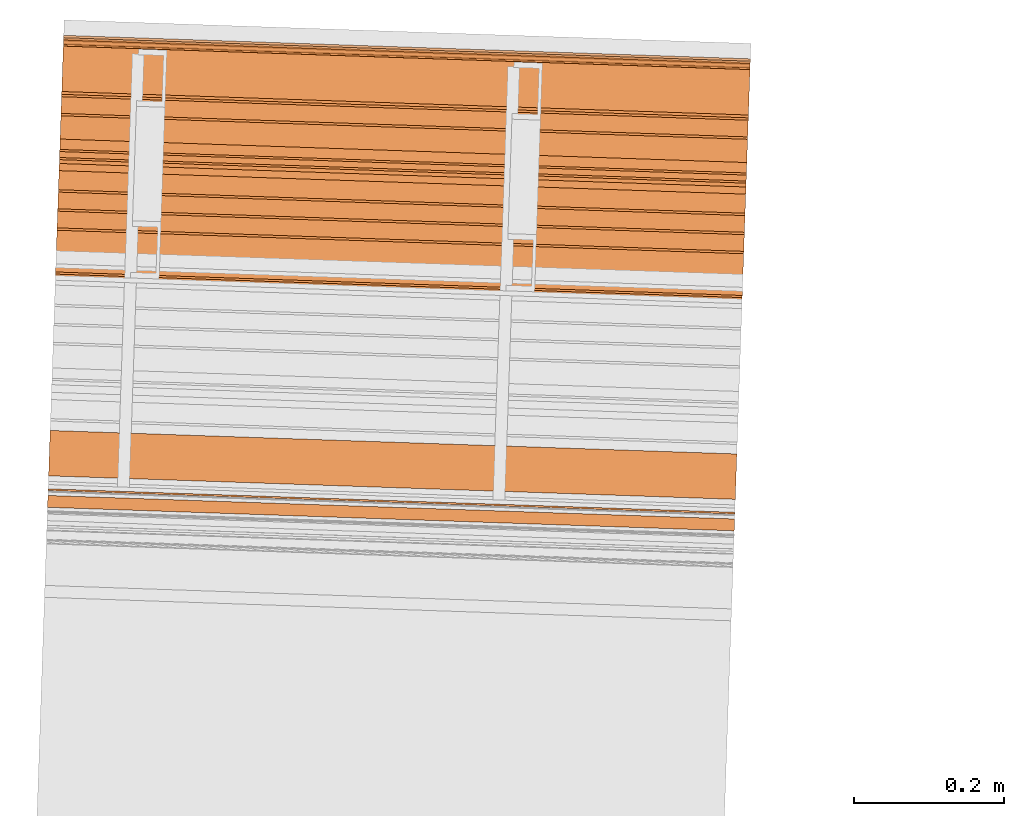
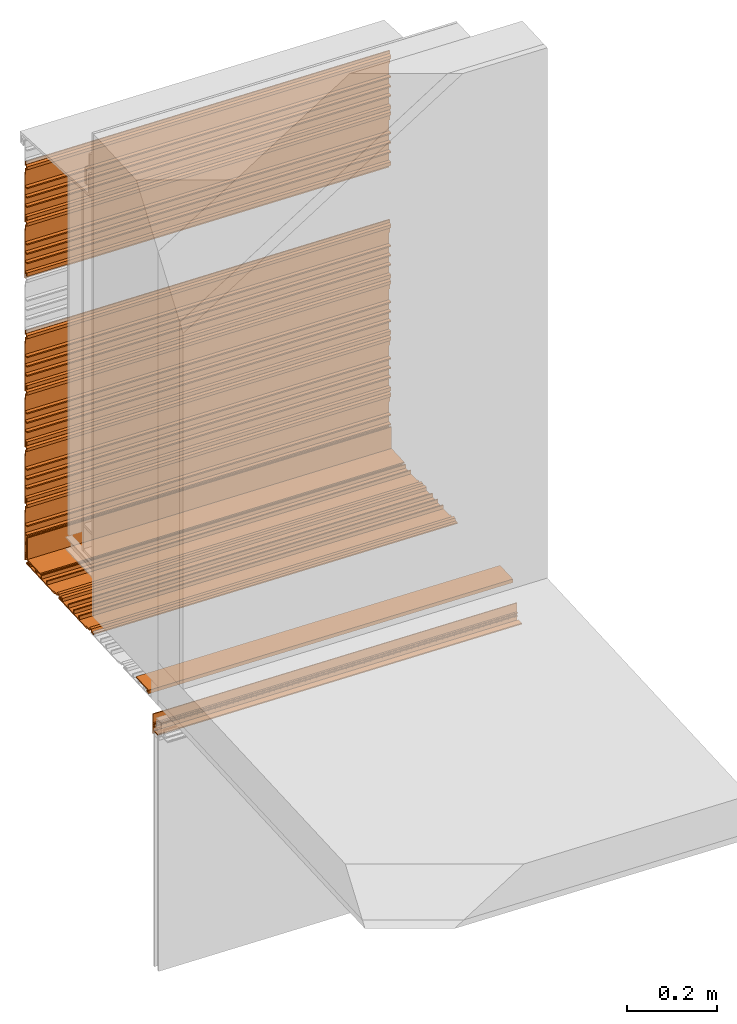
# One storey, part 5 of 7: 13 proxies.
"""IFC2X3 building model written with IfcOpenShell, lengths in feet."""

from ifc_helpers import new_model, entity, si_unit, converted_unit, derived_unit, direction, frame, frame_2d, origin, place, context, subcontext, project, spatial, polyline, circle_curve, parameter, trimmed, segment, composite_curve, outline, extrude, source, transform, mapped, material, type_object, type_shapes, element, save


model = new_model("IFC2X3")

# Units and contexts
model_context = context("Model", 3, precision=0.0001, world=origin(), true_north=direction((6.12303176911189e-17, 1.0)))
context_of_model = context(None, 3, precision=0.0001, world=origin(), true_north=direction((6.12303176911189e-17, 1.0)))
body_context = subcontext(model_context, "Body", "Model", "MODEL_VIEW")
ifc_project = project(units=[converted_unit("LENGTHUNIT", "FOOT", entity("IfcRatioMeasure", 0.3048), si_unit("LENGTHUNIT", "METRE"), dimensions=[1, 0, 0, 0, 0, 0, 0]), converted_unit("AREAUNIT", "SQUARE FOOT", entity("IfcRatioMeasure", 0.09290304), si_unit("AREAUNIT", "SQUARE_METRE"), dimensions=[2, 0, 0, 0, 0, 0, 0]), converted_unit("VOLUMEUNIT", "CUBIC FOOT", entity("IfcRatioMeasure", 0.028316846592), si_unit("VOLUMEUNIT", "CUBIC_METRE"), dimensions=[3, 0, 0, 0, 0, 0, 0]), converted_unit("PLANEANGLEUNIT", "DEGREE", entity("IfcRatioMeasure", 0.0174532925199433), si_unit("PLANEANGLEUNIT", "RADIAN"), dimensions=[0, 0, 0, 0, 0, 0, 0]), si_unit("MASSUNIT", "GRAM", prefix="KILO"), derived_unit("MASSDENSITYUNIT", [(si_unit("MASSUNIT", "GRAM", prefix="KILO"), 1), (si_unit("LENGTHUNIT", "METRE"), -3)]), si_unit("TIMEUNIT", "SECOND"), si_unit("FREQUENCYUNIT", "HERTZ"), si_unit("THERMODYNAMICTEMPERATUREUNIT", "DEGREE_CELSIUS"), derived_unit("THERMALTRANSMITTANCEUNIT", [(si_unit("MASSUNIT", "GRAM", prefix="KILO"), 1), (si_unit("THERMODYNAMICTEMPERATUREUNIT", "KELVIN"), -1), (si_unit("TIMEUNIT", "SECOND"), -3)]), derived_unit("VOLUMETRICFLOWRATEUNIT", [(si_unit("LENGTHUNIT", "METRE"), 3), (si_unit("TIMEUNIT", "SECOND"), -1)]), si_unit("ELECTRICCURRENTUNIT", "AMPERE"), si_unit("ELECTRICVOLTAGEUNIT", "VOLT"), si_unit("POWERUNIT", "WATT"), si_unit("FORCEUNIT", "NEWTON"), si_unit("ILLUMINANCEUNIT", "LUX"), si_unit("LUMINOUSFLUXUNIT", "LUMEN"), si_unit("LUMINOUSINTENSITYUNIT", "CANDELA"), derived_unit("USERDEFINED", [(si_unit("MASSUNIT", "GRAM", prefix="KILO"), -1), (si_unit("LENGTHUNIT", "METRE"), -2), (si_unit("TIMEUNIT", "SECOND"), 3), (si_unit("LUMINOUSFLUXUNIT", "LUMEN"), 1)]), derived_unit("LINEARVELOCITYUNIT", [(si_unit("LENGTHUNIT", "METRE"), 1), (si_unit("TIMEUNIT", "SECOND"), -1)]), si_unit("PRESSUREUNIT", "PASCAL"), derived_unit("USERDEFINED", [(si_unit("LENGTHUNIT", "METRE"), -2), (si_unit("MASSUNIT", "GRAM", prefix="KILO"), 1), (si_unit("TIMEUNIT", "SECOND"), -2)])], contexts=[model_context, context_of_model])

# Site, building, storey
site_placement = place(None, origin())
site = spatial("IfcSite", under=ifc_project, at=site_placement, CompositionType="ELEMENT")
building_placement = place(site_placement, origin())
building = spatial("IfcBuilding", under=site, at=building_placement, CompositionType="ELEMENT")
storey_placement = place(building_placement, origin())
storey = spatial("IfcBuildingStorey", under=building, at=storey_placement, Name="Level 1", CompositionType="ELEMENT", Elevation=0.0)

# Proxies
ifc_material_1 = material(Name="Window frame")
building_element_proxy_type_1 = type_object("IfcBuildingElementProxyType", Name="Window frame 013", PredefinedType="NOTDEFINED", material=ifc_material_1)
shared_shape_1 = source(origin(), body_context, "Body", "SweptSolid", [
    extrude(outline(composite_curve([segment(polyline([(-0.00499999999991374, -0.0259583333333165), (0.00499999999991552, -0.0259583333333165)]), True, "CONTINUOUS"), segment(polyline([(0.00499999999991552, -0.0259583333333165), (0.00499999999991552, 0.0259583333333232)]), True, "CONTINUOUS"), segment(polyline([(0.00499999999991552, 0.0259583333333232), (-0.00499999999991729, 0.0259583333333232)]), True, "CONTINUOUS"), segment(trimmed(circle_curve(frame_2d((-0.138517013888798, 0.0), x_axis=(0.0, 1.0)), 0.13601701388888), [parameter(258.997827097198)], [parameter(281.002172902812)], True, "PARAMETER"), False, "CONTINUOUS")], self_intersect=False)), frame((109.717039781299, -50.5840853372173, 9.44496783238197), z_axis=(0.999414947916633, -0.0342017818365487, 0.0), x_axis=(0.0, 0.0, 1.0)), (0.0, 0.0, 1.0), 3.0),
])
type_shapes(building_element_proxy_type_1, [shared_shape_1])
proxy_1_placement = place(storey_placement, origin())
element("IfcBuildingElementProxy", 1, at=proxy_1_placement, inside=storey, type_object=building_element_proxy_type_1, material=ifc_material_1, Name="Window frame 013:Window frame 013", ObjectType="Window frame 013", context=body_context, shape_type="MappedRepresentation", body=[
    mapped(shared_shape_1, transform((0.0, 0.0, 0.0), scale=1.0)),
])
ifc_material_2 = material()
building_element_proxy_type_2 = type_object("IfcBuildingElementProxyType", Name="panel 015", PredefinedType="NOTDEFINED", material=ifc_material_2)
shared_shape_2 = source(origin(), body_context, "Body", "SweptSolid", [
    extrude(outline(polyline([(-0.0220175316851953, 0.14568014706847), (-0.0220175316851953, -0.291819852931527), (-0.0116008650185187, -0.291819852931527), (-0.0116008650185187, -0.237132352931535), (0.00451787028331154, -0.237132352931535), (0.00451787028331154, -0.257965686264864), (0.0173047730392253, -0.257965686264864), (0.0173047730392253, -0.22671568626486), (-0.0116008650185187, -0.22671568626486), (-0.0116008650185187, -0.143382352931521), (0.0196491349814752, -0.143382352931521), (0.0196491349814752, -0.132965686264869), (-0.0116008650185187, -0.132965686264869), (-0.0116008650185187, -0.0600490195981838), (0.0196491349814752, -0.0600490195981838), (0.0196491349814752, -0.0496323529315301), (-0.0116008650185187, -0.0496323529315301), (-0.0116008650185187, 0.0232843137351306), (0.0196491349814752, 0.0232843137351306), (0.0196491349814752, 0.0337009804018074), (-0.0116008650185187, 0.0337009804018074), (-0.0116008650185187, 0.135263480401818), (-0.00118419835184916, 0.135263480401818), (-0.00118419835184916, 0.180710665113098), (0.0186287630982651, 0.18994960080863), (0.0186287630982651, 0.215994026661651), (-0.00118419835184916, 0.225232962029096), (-0.00118419835184916, 0.249846813735136), (-0.0116008650185187, 0.249846813735136), (-0.0116008650185187, 0.218596813735131), (0.0061931721533835, 0.210299318000233), (0.0061931721533835, 0.195644309470049), (-0.0116008650185187, 0.18734681373515), (-0.0116008650185187, 0.14568014706847), (-0.0220175316851953, 0.14568014706847)])), frame((109.785926286855, -48.5711433305344, 10.521009163627), z_axis=(-0.999414947916601, 0.034201781837477, 0.0), x_axis=(-0.034201781837477, -0.999414947916601, 0.0)), (0.0, 0.0, -1.0), 3.0),
])
type_shapes(building_element_proxy_type_2, [shared_shape_2])
proxy_2_placement = place(storey_placement, origin())
element("IfcBuildingElementProxy", 2, at=proxy_2_placement, inside=storey, type_object=building_element_proxy_type_2, material=ifc_material_2, Name="panel 015:panel 015", ObjectType="panel 015", context=body_context, shape_type="MappedRepresentation", body=[
    mapped(shared_shape_2, transform((0.0, 0.0, 0.0), scale=1.0)),
])
building_element_proxy_type_3 = type_object("IfcBuildingElementProxyType", Name="panel 019", PredefinedType="NOTDEFINED", material=ifc_material_2)
shared_shape_3 = source(origin(), body_context, "Body", "SweptSolid", [
    extrude(outline(polyline([(-0.0220175316851953, 0.145680147068473), (-0.0220175316851953, -0.291819852931525), (-0.0116008650185187, -0.291819852931525), (-0.0116008650185187, -0.237132352931534), (0.00451787028331154, -0.237132352931534), (0.00451787028331154, -0.257965686264862), (0.0173047730392253, -0.257965686264862), (0.0173047730392253, -0.226715686264859), (-0.0116008650185187, -0.226715686264859), (-0.0116008650185187, -0.143382352931518), (0.0196491349814752, -0.143382352931518), (0.0196491349814752, -0.132965686264868), (-0.0116008650185187, -0.132965686264868), (-0.0116008650185187, -0.0600490195981802), (0.0196491349814752, -0.0600490195981802), (0.0196491349814752, -0.0496323529315266), (-0.0116008650185187, -0.0496323529315266), (-0.0116008650185187, 0.0232843137351324), (0.0196491349814752, 0.0232843137351324), (0.0196491349814752, 0.0337009804018109), (-0.0116008650185187, 0.0337009804018109), (-0.0116008650185187, 0.13526348040182), (-0.00118419835184916, 0.13526348040182), (-0.00118419835184916, 0.1807106651131), (0.0186287630982651, 0.189949600808632), (0.0186287630982651, 0.215994026661653), (-0.00118419835184916, 0.2252329620291), (-0.00118419835184916, 0.24984681373514), (-0.0116008650185187, 0.24984681373514), (-0.0116008650185187, 0.218596813735132), (0.0061931721533835, 0.210299318000237), (0.0061931721533835, 0.195644309470051), (-0.0116008650185187, 0.187346813735154), (-0.0116008650185187, 0.145680147068473), (-0.0220175316851953, 0.145680147068473)])), frame((109.785926286855, -48.5711433305344, 13.021009163627), z_axis=(-0.999414947916601, 0.034201781837477, 0.0), x_axis=(-0.034201781837477, -0.999414947916601, 0.0)), (0.0, 0.0, -1.0), 3.0),
])
type_shapes(building_element_proxy_type_3, [shared_shape_3])
proxy_3_placement = place(storey_placement, origin())
element("IfcBuildingElementProxy", 3, at=proxy_3_placement, inside=storey, type_object=building_element_proxy_type_3, material=ifc_material_2, Name="panel 019:panel 019", ObjectType="panel 019", context=body_context, shape_type="MappedRepresentation", body=[
    mapped(shared_shape_3, transform((0.0, 0.0, 0.0), scale=1.0)),
])
building_element_proxy_type_4 = type_object("IfcBuildingElementProxyType", Name="panel 024", PredefinedType="NOTDEFINED", material=ifc_material_2)
shared_shape_4 = source(origin(), body_context, "Body", "SweptSolid", [
    extrude(outline(polyline([(-0.0220175316851953, 0.145680147068473), (-0.0220175316851953, -0.291819852931523), (-0.0116008650185187, -0.291819852931523), (-0.0116008650185187, -0.237132352931534), (0.00451787028331154, -0.237132352931534), (0.00451787028331154, -0.257965686264862), (0.0173047730392253, -0.257965686264862), (0.0173047730392253, -0.226715686264857), (-0.0116008650185187, -0.226715686264857), (-0.0116008650185187, -0.143382352931519), (0.0196491349814752, -0.143382352931519), (0.0196491349814752, -0.132965686264866), (-0.0116008650185187, -0.132965686264866), (-0.0116008650185187, -0.0600490195981802), (0.0196491349814752, -0.0600490195981802), (0.0196491349814752, -0.0496323529315283), (-0.0116008650185187, -0.0496323529315283), (-0.0116008650185187, 0.0232843137351342), (0.0196491349814752, 0.0232843137351342), (0.0196491349814752, 0.0337009804018091), (-0.0116008650185187, 0.0337009804018091), (-0.0116008650185187, 0.13526348040182), (-0.00118419835184916, 0.13526348040182), (-0.00118419835184916, 0.1807106651131), (0.0186287630982651, 0.189949600808632), (0.0186287630982651, 0.215994026661653), (-0.00118419835184916, 0.2252329620291), (-0.00118419835184916, 0.249846813735138), (-0.0116008650185187, 0.249846813735138), (-0.0116008650185187, 0.218596813735134), (0.0061931721533835, 0.210299318000235), (0.0061931721533835, 0.195644309470051), (-0.0116008650185187, 0.187346813735154), (-0.0116008650185187, 0.145680147068473), (-0.0220175316851953, 0.145680147068473)])), frame((109.785926286855, -48.5711433305344, 10.021009163627), z_axis=(-0.999414947916601, 0.034201781837477, 0.0), x_axis=(-0.034201781837477, -0.999414947916601, 0.0)), (0.0, 0.0, -1.0), 3.0),
])
type_shapes(building_element_proxy_type_4, [shared_shape_4])
proxy_4_placement = place(storey_placement, origin())
element("IfcBuildingElementProxy", 4, at=proxy_4_placement, inside=storey, type_object=building_element_proxy_type_4, material=ifc_material_2, Name="panel 024:panel 024", ObjectType="panel 024", context=body_context, shape_type="MappedRepresentation", body=[
    mapped(shared_shape_4, transform((0.0, 0.0, 0.0), scale=1.0)),
])
building_element_proxy_type_5 = type_object("IfcBuildingElementProxyType", Name="panel 017", PredefinedType="NOTDEFINED", material=ifc_material_2)
shared_shape_5 = source(origin(), body_context, "Body", "SweptSolid", [
    extrude(outline(polyline([(-0.291819852941174, -0.011600865003091), (-0.291819852941174, -0.0220175316697446), (0.145680147058836, -0.0220175316697446), (0.145680147058836, -0.011600865003091), (0.187346813725485, -0.011600865003091), (0.195644309526024, 0.00619317207041981), (0.210299317924975, 0.00619317207041981), (0.218596813725506, -0.011600865003091), (0.249846813725521, -0.011600865003091), (0.249846813725521, -0.00118419833641603), (0.225232962281941, -0.00118419833641603), (0.215994026619209, 0.0186287629496675), (0.18994960083181, 0.0186287629496675), (0.180710665169079, -0.00118419833641603), (0.135263480392167, -0.00118419833641603), (0.135263480392167, -0.011600865003091), (0.0337009803921559, -0.011600865003091), (0.0337009803921559, 0.0196491349969126), (0.0232843137255081, 0.0196491349969126), (0.0232843137255081, -0.011600865003091), (-0.0496323529411615, -0.011600865003091), (-0.0496323529411615, 0.0196491349969126), (-0.0600490196078306, 0.0196491349969126), (-0.0600490196078306, -0.011600865003091), (-0.1329656862745, -0.011600865003091), (-0.1329656862745, 0.0196491349969126), (-0.143382352941169, 0.0196491349969126), (-0.143382352941169, -0.011600865003091), (-0.226715686274508, -0.011600865003091), (-0.226715686274508, 0.0173047731202818), (-0.25796568627448, 0.0173047731202818), (-0.25796568627448, 0.00451787023313344), (-0.237132352941156, 0.00451787023313344), (-0.237132352941156, -0.011600865003091), (-0.291819852941174, -0.011600865003091)])), frame((109.758707004404, -49.366521708274, 9.73037350903191), z_axis=(-0.99941494791664, 0.034201781836329, 0.0), x_axis=(-0.034201781836329, -0.99941494791664, 0.0)), (0.0, 0.0, -1.0), 3.0),
])
type_shapes(building_element_proxy_type_5, [shared_shape_5])
proxy_5_placement = place(storey_placement, origin())
element("IfcBuildingElementProxy", 5, at=proxy_5_placement, inside=storey, type_object=building_element_proxy_type_5, material=ifc_material_2, Name="panel 017:panel 017", ObjectType="panel 017", context=body_context, shape_type="MappedRepresentation", body=[
    mapped(shared_shape_5, transform((0.0, 0.0, 0.0), scale=1.0)),
])
building_element_proxy_type_6 = type_object("IfcBuildingElementProxyType", Name="panel 014", PredefinedType="NOTDEFINED", material=ifc_material_2)
shared_shape_6 = source(origin(), body_context, "Body", "SweptSolid", [
    extrude(outline(polyline([(-0.0220175316851953, 0.145680147068475), (-0.0220175316851953, -0.291819852931521), (-0.0116008650185187, -0.291819852931521), (-0.0116008650185187, -0.237132352931532), (0.00451787028331154, -0.237132352931532), (0.00451787028331154, -0.25796568626486), (0.0173047730392253, -0.25796568626486), (0.0173047730392253, -0.226715686264855), (-0.0116008650185187, -0.226715686264855), (-0.0116008650185187, -0.143382352931516), (0.0196491349814752, -0.143382352931516), (0.0196491349814752, -0.132965686264864), (-0.0116008650185187, -0.132965686264864), (-0.0116008650185187, -0.0600490195981784), (0.0196491349814752, -0.0600490195981784), (0.0196491349814752, -0.0496323529315248), (-0.0116008650185187, -0.0496323529315248), (-0.0116008650185187, 0.023284313735136), (0.0196491349814752, 0.023284313735136), (0.0196491349814752, 0.0337009804018127), (-0.0116008650185187, 0.0337009804018127), (-0.0116008650185187, 0.135263480401822), (-0.00118419835184916, 0.135263480401822), (-0.00118419835184916, 0.180710665113102), (0.0186287630982651, 0.189949600808633), (0.0186287630982651, 0.215994026661656), (-0.00118419835184916, 0.225232962029102), (-0.00118419835184916, 0.249846813735141), (-0.0116008650185187, 0.249846813735141), (-0.0116008650185187, 0.218596813735136), (0.0061931721533835, 0.210299318000239), (0.0061931721533835, 0.195644309470053), (-0.0116008650185187, 0.187346813735155), (-0.0116008650185187, 0.145680147068475), (-0.0220175316851953, 0.145680147068475)])), frame((109.785926286855, -48.5711433305344, 11.521009163627), z_axis=(-0.999414947916601, 0.034201781837477, 0.0), x_axis=(-0.034201781837477, -0.999414947916601, 0.0)), (0.0, 0.0, -1.0), 3.0),
])
type_shapes(building_element_proxy_type_6, [shared_shape_6])
proxy_6_placement = place(storey_placement, origin())
element("IfcBuildingElementProxy", 6, at=proxy_6_placement, inside=storey, type_object=building_element_proxy_type_6, material=ifc_material_2, Name="panel 014:panel 014", ObjectType="panel 014", context=body_context, shape_type="MappedRepresentation", body=[
    mapped(shared_shape_6, transform((0.0, 0.0, 0.0), scale=1.0)),
])
building_element_proxy_type_7 = type_object("IfcBuildingElementProxyType", Name="panel 016", PredefinedType="NOTDEFINED", material=ifc_material_2)
shared_shape_7 = source(origin(), body_context, "Body", "SweptSolid", [
    extrude(outline(polyline([(-0.291819852941177, -0.011600865003091), (-0.291819852941177, -0.0220175316697446), (0.145680147058838, -0.0220175316697446), (0.145680147058838, -0.011600865003091), (0.187346813725486, -0.011600865003091), (0.195644309526018, 0.00619317207041981), (0.21029931792497, 0.00619317207041981), (0.218596813725501, -0.011600865003091), (0.249846813725523, -0.011600865003091), (0.249846813725523, -0.00118419833641603), (0.225232962281936, -0.00118419833641603), (0.215994026619204, 0.0186287629496675), (0.189949600831812, 0.0186287629496675), (0.18071066516908, -0.00118419833641603), (0.135263480392162, -0.00118419833641603), (0.135263480392162, -0.011600865003091), (0.0337009803921564, -0.011600865003091), (0.0337009803921564, 0.0196491349969126), (0.0232843137255015, 0.0196491349969126), (0.0232843137255015, -0.011600865003091), (-0.049632352941162, -0.011600865003091), (-0.049632352941162, 0.0196491349969126), (-0.0600490196078382, 0.0196491349969126), (-0.0600490196078382, -0.011600865003091), (-0.132965686274501, -0.011600865003091), (-0.132965686274501, 0.0196491349969126), (-0.143382352941171, 0.0196491349969126), (-0.143382352941171, -0.011600865003091), (-0.22671568627451, -0.011600865003091), (-0.22671568627451, 0.0173047731202818), (-0.257965686274482, 0.0173047731202818), (-0.257965686274482, 0.00451787023313344), (-0.237132352941165, 0.00451787023313344), (-0.237132352941165, -0.011600865003091), (-0.291819852941177, -0.011600865003091)])), frame((109.775807895322, -48.8668142343156, 9.73037350903191), z_axis=(-0.999414947916631, 0.034201781836593, 0.0), x_axis=(-0.034201781836593, -0.999414947916631, 0.0)), (0.0, 0.0, -1.0), 2.99999999999999),
])
type_shapes(building_element_proxy_type_7, [shared_shape_7])
proxy_7_placement = place(storey_placement, origin())
element("IfcBuildingElementProxy", 7, at=proxy_7_placement, inside=storey, type_object=building_element_proxy_type_7, material=ifc_material_2, Name="panel 016:panel 016", ObjectType="panel 016", context=body_context, shape_type="MappedRepresentation", body=[
    mapped(shared_shape_7, transform((0.0, 0.0, 0.0), scale=1.0)),
])
building_element_proxy_type_8 = type_object("IfcBuildingElementProxyType", Name="panel 023", PredefinedType="NOTDEFINED", material=ifc_material_2)
shared_shape_8 = source(origin(), body_context, "Body", "SweptSolid", [
    extrude(outline(polyline([(-0.0220175316851953, 0.145680147068472), (-0.0220175316851953, -0.291819852931525), (-0.0116008650185187, -0.291819852931525), (-0.0116008650185187, -0.237132352931534), (0.00451787028331154, -0.237132352931534), (0.00451787028331154, -0.257965686264862), (0.0173047730392253, -0.257965686264862), (0.0173047730392253, -0.226715686264859), (-0.0116008650185187, -0.226715686264859), (-0.0116008650185187, -0.143382352931519), (0.0196491349814752, -0.143382352931519), (0.0196491349814752, -0.132965686264868), (-0.0116008650185187, -0.132965686264868), (-0.0116008650185187, -0.0600490195981802), (0.0196491349814752, -0.0600490195981802), (0.0196491349814752, -0.0496323529315283), (-0.0116008650185187, -0.0496323529315283), (-0.0116008650185187, 0.0232843137351324), (0.0196491349814752, 0.0232843137351324), (0.0196491349814752, 0.0337009804018091), (-0.0116008650185187, 0.0337009804018091), (-0.0116008650185187, 0.13526348040182), (-0.00118419835184916, 0.13526348040182), (-0.00118419835184916, 0.1807106651131), (0.0186287630982651, 0.189949600808632), (0.0186287630982651, 0.215994026661653), (-0.00118419835184916, 0.225232962029098), (-0.00118419835184916, 0.249846813735138), (-0.0116008650185187, 0.249846813735138), (-0.0116008650185187, 0.218596813735132), (0.0061931721533835, 0.210299318000235), (0.0061931721533835, 0.195644309470051), (-0.0116008650185187, 0.187346813735152), (-0.0116008650185187, 0.145680147068472), (-0.0220175316851953, 0.145680147068472)])), frame((109.785926286855, -48.5711433305344, 11.021009163627), z_axis=(-0.999414947916601, 0.034201781837477, 0.0), x_axis=(-0.034201781837477, -0.999414947916601, 0.0)), (0.0, 0.0, -1.0), 3.0),
])
type_shapes(building_element_proxy_type_8, [shared_shape_8])
proxy_8_placement = place(storey_placement, origin())
element("IfcBuildingElementProxy", 8, at=proxy_8_placement, inside=storey, type_object=building_element_proxy_type_8, material=ifc_material_2, Name="panel 023:panel 023", ObjectType="panel 023", context=body_context, shape_type="MappedRepresentation", body=[
    mapped(shared_shape_8, transform((0.0, 0.0, 0.0), scale=1.0)),
])
ifc_material_3 = material(Name="IfcSurfaceStyle #179")
building_element_proxy_type_9 = type_object("IfcBuildingElementProxyType", Name="starter strip 006", PredefinedType="NOTDEFINED", material=ifc_material_3)
shared_shape_9 = source(origin(), body_context, "Body", "SweptSolid", [
    extrude(outline(polyline([(-0.00592609117454079, -0.050489778625332), (-0.00592609117454079, -0.0251609571030116), (-0.0154211444225639, -0.0251609571030116), (-0.0154211444225639, -0.061359485646328), (0.015963096620743, -0.061359485646328), (0.015963096620743, 0.137010221374673), (0.00538413897639667, 0.137010221374673), (0.00538413897639667, -0.050489778625332), (-0.00592609117454079, -0.050489778625332)])), frame((109.785617492212, -48.5801666610631, 9.81008004634185), z_axis=(-0.999414947916641, 0.0342017818363039, 0.0), x_axis=(-0.0342017818363039, -0.999414947916641, 0.0)), (0.0, 0.0, -1.0), 2.99999999999999),
])
type_shapes(building_element_proxy_type_9, [shared_shape_9])
proxy_9_placement = place(storey_placement, origin())
element("IfcBuildingElementProxy", 9, at=proxy_9_placement, inside=storey, type_object=building_element_proxy_type_9, material=ifc_material_3, Name="starter strip 006:starter strip 006", ObjectType="starter strip 006", context=body_context, shape_type="MappedRepresentation", body=[
    mapped(shared_shape_9, transform((0.0, 0.0, 0.0), scale=1.0)),
])
building_element_proxy_type_10 = type_object("IfcBuildingElementProxyType", Name="panel 013", PredefinedType="NOTDEFINED", material=ifc_material_2)
shared_shape_10 = source(origin(), body_context, "Body", "SweptSolid", [
    extrude(outline(polyline([(-0.0220175316851953, 0.145680147068475), (-0.0220175316851953, -0.291819852931521), (-0.0116008650185187, -0.291819852931521), (-0.0116008650185187, -0.237132352931532), (0.00451787028331154, -0.237132352931532), (0.00451787028331154, -0.25796568626486), (0.0173047730392253, -0.25796568626486), (0.0173047730392253, -0.226715686264855), (-0.0116008650185187, -0.226715686264855), (-0.0116008650185187, -0.143382352931518), (0.0196491349814752, -0.143382352931518), (0.0196491349814752, -0.132965686264864), (-0.0116008650185187, -0.132965686264864), (-0.0116008650185187, -0.0600490195981784), (0.0196491349814752, -0.0600490195981784), (0.0196491349814752, -0.0496323529315248), (-0.0116008650185187, -0.0496323529315248), (-0.0116008650185187, 0.023284313735136), (0.0196491349814752, 0.023284313735136), (0.0196491349814752, 0.0337009804018109), (-0.0116008650185187, 0.0337009804018109), (-0.0116008650185187, 0.135263480401822), (-0.00118419835184916, 0.135263480401822), (-0.00118419835184916, 0.180710665113102), (0.0186287630982651, 0.189949600808633), (0.0186287630982651, 0.215994026661654), (-0.00118419835184916, 0.225232962029102), (-0.00118419835184916, 0.24984681373514), (-0.0116008650185187, 0.24984681373514), (-0.0116008650185187, 0.218596813735136), (0.0061931721533835, 0.210299318000237), (0.0061931721533835, 0.195644309470053), (-0.0116008650185187, 0.187346813735155), (-0.0116008650185187, 0.145680147068475), (-0.0220175316851953, 0.145680147068475)])), frame((109.785926286855, -48.5711433305344, 12.521009163627), z_axis=(-0.999414947916601, 0.034201781837477, 0.0), x_axis=(-0.034201781837477, -0.999414947916601, 0.0)), (0.0, 0.0, -1.0), 3.0),
])
type_shapes(building_element_proxy_type_10, [shared_shape_10])
proxy_10_placement = place(storey_placement, origin())
element("IfcBuildingElementProxy", 10, at=proxy_10_placement, inside=storey, type_object=building_element_proxy_type_10, material=ifc_material_2, Name="panel 013:panel 013", ObjectType="panel 013", context=body_context, shape_type="MappedRepresentation", body=[
    mapped(shared_shape_10, transform((0.0, 0.0, 0.0), scale=1.0)),
])
building_element_proxy_type_11 = type_object("IfcBuildingElementProxyType", Name="starter strip 004", PredefinedType="NOTDEFINED", material=ifc_material_3)
shared_shape_11 = source(origin(), body_context, "Body", "SweptSolid", [
    extrude(outline(polyline([(-0.0154211442749261, -0.0613594857283405), (0.0159630965387123, -0.0613594857283405), (0.0159630965387123, 0.137010221423876), (0.00538413886154032, 0.137010221423876), (0.00538413886154032, -0.0504897785761173), (-0.00592609112533005, -0.0504897785761173), (-0.00592609112533005, -0.0251609571194176), (-0.0154211442749261, -0.0251609571194176), (-0.0154211442749261, -0.0613594857283405)])), frame((109.782968627618, -48.657569495894, 9.74081747039039), z_axis=(0.999414947916646, -0.0342017818361628, 0.0), x_axis=(0.0, 0.0, 1.0)), (0.0, 0.0, 1.0), 3.0),
])
type_shapes(building_element_proxy_type_11, [shared_shape_11])
proxy_11_placement = place(storey_placement, origin())
element("IfcBuildingElementProxy", 11, at=proxy_11_placement, inside=storey, type_object=building_element_proxy_type_11, material=ifc_material_3, Name="starter strip 004:starter strip 004", ObjectType="starter strip 004", context=body_context, shape_type="MappedRepresentation", body=[
    mapped(shared_shape_11, transform((0.0, 0.0, 0.0), scale=1.0)),
])
building_element_proxy_type_12 = type_object("IfcBuildingElementProxyType", Name="starter strip 005", PredefinedType="NOTDEFINED", material=ifc_material_3)
shared_shape_12 = source(origin(), body_context, "Body", "SweptSolid", [
    extrude(outline(polyline([(-0.00592609117455467, -0.050489778625324), (-0.00592609117455467, -0.0251609571030094), (-0.0154211444225663, -0.0251609571030094), (-0.0154211444225663, -0.0613594856463255), (0.0159630966207374, -0.0613594856463255), (0.0159630966207374, 0.13701022137468), (0.00538413897638179, 0.13701022137468), (0.00538413897638179, -0.050489778625324), (-0.00592609117455467, -0.050489778625324)])), frame((109.722955483837, -50.4112217837229, 9.74081747030829), z_axis=(-0.999414947916628, 0.0342017818366754, 0.0), x_axis=(0.0, 0.0, 1.0)), (0.0, 0.0, -1.0), 3.0),
])
type_shapes(building_element_proxy_type_12, [shared_shape_12])
proxy_12_placement = place(storey_placement, origin())
element("IfcBuildingElementProxy", 12, at=proxy_12_placement, inside=storey, type_object=building_element_proxy_type_12, material=ifc_material_3, Name="starter strip 005:starter strip 005", ObjectType="starter strip 005", context=body_context, shape_type="MappedRepresentation", body=[
    mapped(shared_shape_12, transform((0.0, 0.0, 0.0), scale=1.0)),
])
building_element_proxy_type_13 = type_object("IfcBuildingElementProxyType", Name="Window frame 016", PredefinedType="NOTDEFINED", material=ifc_material_1)
shared_shape_13 = source(origin(), body_context, "Body", "SweptSolid", [
    extrude(outline(composite_curve([segment(trimmed(circle_curve(frame_2d((0.00560116958344474, -0.0105069444443782), x_axis=(1.0, 0.0)), 0.00208333333333355), [parameter(359.999999999951)], [parameter(180.0)], True, "PARAMETER"), True, "CONTINUOUS"), segment(trimmed(circle_curve(frame_2d((0.00143450291647657, -0.0105069444443782), x_axis=(1.0, 0.0)), 0.00208333333333194), [parameter(270.0)], [parameter(0.0)], True, "PARAMETER"), False, "CONTINUOUS"), segment(polyline([(0.00143450291647657, -0.0125902777777096), (-0.00206549708348842, -0.0125902777778002)]), True, "CONTINUOUS"), segment(trimmed(circle_curve(frame_2d((-0.00206549708348842, -0.0105069444443782), x_axis=(1.0, 0.0)), 0.00208333333333249), [parameter(180.0)], [parameter(270.0)], True, "PARAMETER"), False, "CONTINUOUS"), segment(polyline([(-0.00414883041681959, -0.0105069444443782), (-0.00414883041661929, 0.00999305555563446)]), True, "CONTINUOUS"), segment(trimmed(circle_curve(frame_2d((-0.00206549708348745, 0.00999305555563446), x_axis=(1.0, 0.0)), 0.00208333333333313), [parameter(90.0000000000001)], [parameter(180.0)], True, "PARAMETER"), False, "CONTINUOUS"), segment(polyline([(-0.00206549708348745, 0.0120763888889677), (0.00143450291647803, 0.0120763888888664)]), True, "CONTINUOUS"), segment(trimmed(circle_curve(frame_2d((0.00143450291647803, 0.00999305555563446), x_axis=(1.0, 0.0)), 0.00208333333333237), [parameter(0.0)], [parameter(90.0000000000001)], True, "PARAMETER"), False, "CONTINUOUS"), segment(trimmed(circle_curve(frame_2d((0.00560116958344571, 0.00999305555563446), x_axis=(1.0, 0.0)), 0.00208333333333355), [parameter(180.0)], [parameter(0.0)], True, "PARAMETER"), True, "CONTINUOUS"), segment(polyline([(0.00768450291677688, 0.00999305555563446), (0.00768450291672007, 0.0146597222220066)]), True, "CONTINUOUS"), segment(trimmed(circle_curve(frame_2d((0.00510116958329158, 0.0146597222220066), x_axis=(1.0, 0.0)), 0.00258333333333234), [parameter(0.0)], [parameter(90.0000000000001)], True, "PARAMETER"), True, "CONTINUOUS"), segment(polyline([(0.00510116958329158, 0.0172430555553387), (-0.00231549708326933, 0.0172430555555323)]), True, "CONTINUOUS"), segment(polyline([(-0.00231549708326933, 0.0172430555555323), (-0.00231549708326642, 0.0755763888888659)]), True, "CONTINUOUS"), segment(polyline([(-0.00231549708326642, 0.0755763888888659), (-0.00748216374994586, 0.0755763888888659)]), True, "CONTINUOUS"), segment(polyline([(-0.00748216374994586, 0.0755763888888659), (-0.00748216374994586, 0.0797430555555323)]), True, "CONTINUOUS"), segment(polyline([(-0.00748216374994586, 0.0797430555555323), (-0.0108154970832829, 0.0797430555555323)]), True, "CONTINUOUS"), segment(polyline([(-0.0108154970832829, 0.0797430555555323), (-0.0108154970832846, -0.0973402777777999)]), True, "CONTINUOUS"), segment(polyline([(-0.0108154970832846, -0.0973402777777999), (-0.00306549708326136, -0.0973402777777999)]), True, "CONTINUOUS"), segment(polyline([(-0.00306549708326136, -0.0973402777777999), (-0.00414883041661753, -0.0921736111111322)]), True, "CONTINUOUS"), segment(polyline([(-0.00414883041661753, -0.0921736111111322), (-0.00414883041662075, -0.0192569444444661)]), True, "CONTINUOUS"), segment(polyline([(-0.00414883041662075, -0.0192569444444661), (0.00642309958337842, -0.0192569444444661)]), True, "CONTINUOUS"), segment(polyline([(0.00642309958337842, -0.0192569444444661), (0.0102678362500619, -0.0192569444444661)]), True, "CONTINUOUS"), segment(polyline([(0.0102678362500619, -0.0192569444444661), (0.0102678362500624, -0.0125902777778002)]), True, "CONTINUOUS"), segment(polyline([(0.0102678362500624, -0.0125902777778002), (0.00768450291677591, -0.0105069444443782)]), True, "CONTINUOUS")], self_intersect=False)), frame((109.718553820177, -50.5398433999572, 9.48804422127076), z_axis=(0.999414947916632, -0.0342017818365531, 0.0), x_axis=(-0.0342017818365531, -0.999414947916632, 0.0)), (0.0, 0.0, 1.0), 3.0),
])
type_shapes(building_element_proxy_type_13, [shared_shape_13])
proxy_13_placement = place(storey_placement, origin())
element("IfcBuildingElementProxy", 13, at=proxy_13_placement, inside=storey, type_object=building_element_proxy_type_13, material=ifc_material_1, Name="Window frame 016:Window frame 016", ObjectType="Window frame 016", context=body_context, shape_type="MappedRepresentation", body=[
    mapped(shared_shape_13, transform((0.0, 0.0, 0.0), scale=1.0)),
])

save(model, "model.ifc")
